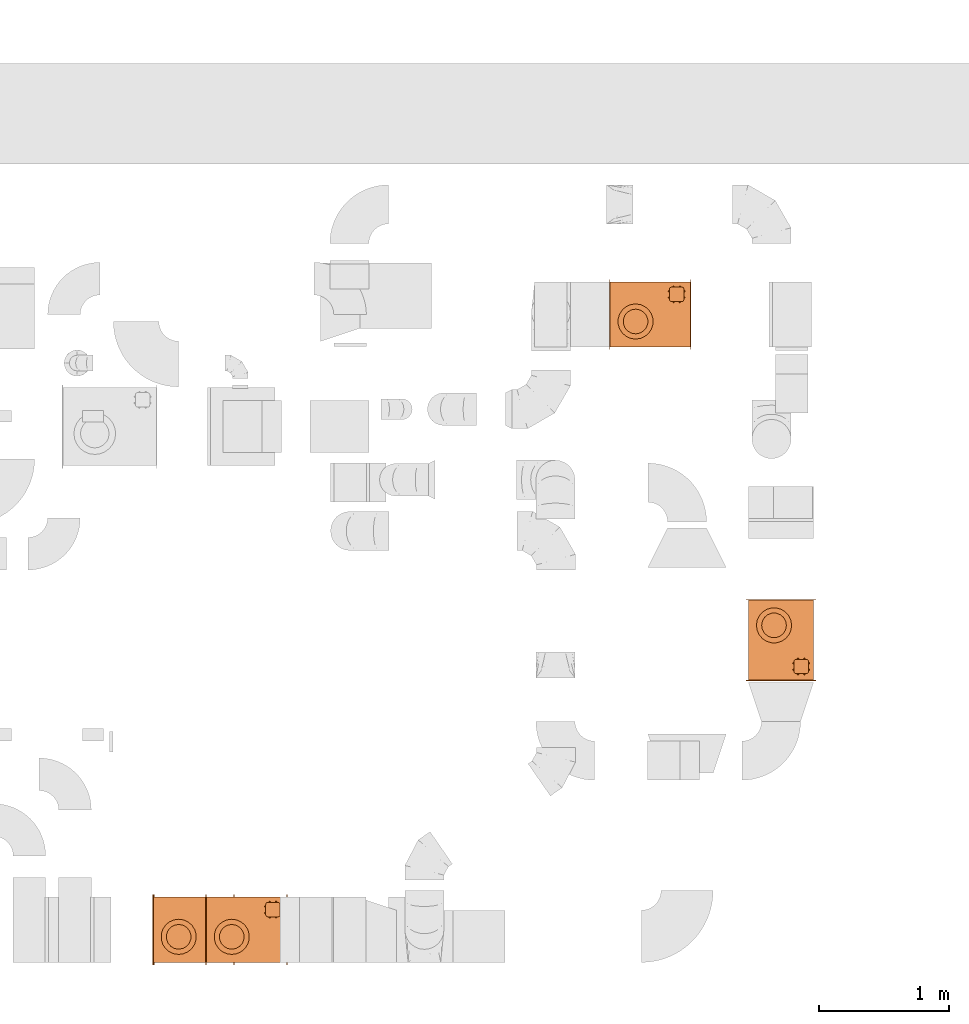
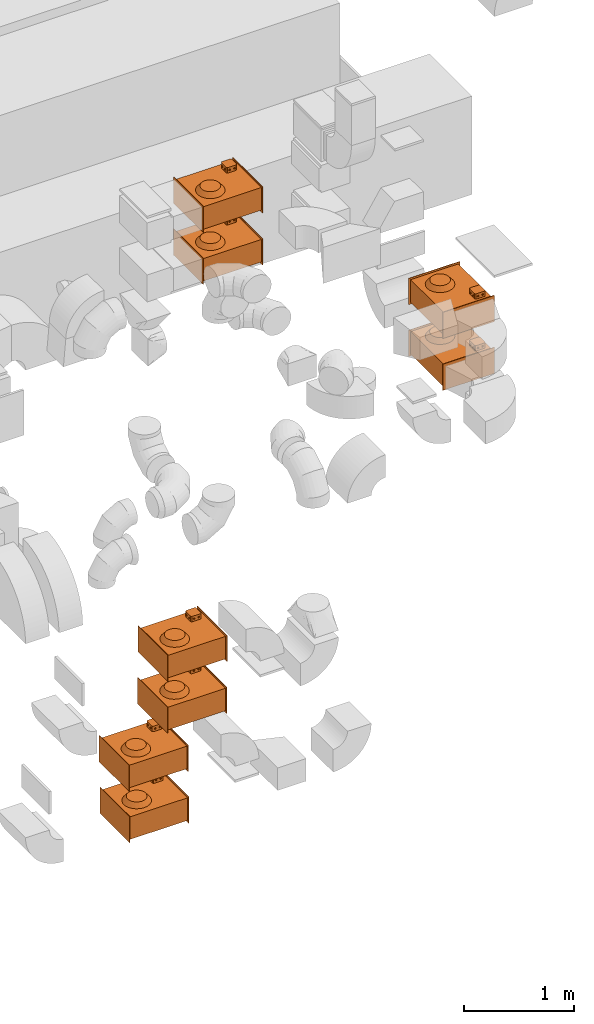
# One storey, part 59 of 59: 8 proxies.
"""IFC2X3 building model written with IfcOpenShell, lengths in millimetres."""

from ifc_helpers import new_model, entity, si_unit, converted_unit, derived_unit, direction, frame, origin, place, context, subcontext, project, spatial, faceted_brep, source, transform, mapped, material, material_list, type_object, type_shapes, element, save


model = new_model("IFC2X3")

# Units and contexts
model_context = context("Model", 3, precision=0.01, world=origin(), true_north=direction((6.12303176911189e-17, 1.0)))
body_context = subcontext(model_context, "Body", "Model", "MODEL_VIEW")
ifc_project = project(units=[si_unit("LENGTHUNIT", "METRE", prefix="MILLI"), si_unit("AREAUNIT", "SQUARE_METRE"), si_unit("VOLUMEUNIT", "CUBIC_METRE"), converted_unit("PLANEANGLEUNIT", "DEGREE", entity("IfcRatioMeasure", 0.0174532925199433), si_unit("PLANEANGLEUNIT", "RADIAN"), dimensions=[0, 0, 0, 0, 0, 0, 0]), si_unit("MASSUNIT", "GRAM", prefix="KILO"), derived_unit("MASSDENSITYUNIT", [(si_unit("MASSUNIT", "GRAM", prefix="KILO"), 1), (si_unit("LENGTHUNIT", "METRE"), -3)]), derived_unit("MOMENTOFINERTIAUNIT", [(si_unit("LENGTHUNIT", "METRE"), 4)]), si_unit("TIMEUNIT", "SECOND"), si_unit("FREQUENCYUNIT", "HERTZ"), si_unit("THERMODYNAMICTEMPERATUREUNIT", "DEGREE_CELSIUS"), derived_unit("THERMALTRANSMITTANCEUNIT", [(si_unit("MASSUNIT", "GRAM", prefix="KILO"), 1), (si_unit("THERMODYNAMICTEMPERATUREUNIT", "KELVIN"), -1), (si_unit("TIMEUNIT", "SECOND"), -3)]), derived_unit("VOLUMETRICFLOWRATEUNIT", [(si_unit("LENGTHUNIT", "METRE"), 3), (si_unit("TIMEUNIT", "SECOND"), -1)]), derived_unit("MASSFLOWRATEUNIT", [(si_unit("MASSUNIT", "GRAM", prefix="KILO"), 1), (si_unit("TIMEUNIT", "SECOND"), -1)]), derived_unit("ROTATIONALFREQUENCYUNIT", [(si_unit("TIMEUNIT", "SECOND"), -1)]), si_unit("ELECTRICCURRENTUNIT", "AMPERE"), si_unit("ELECTRICVOLTAGEUNIT", "VOLT"), si_unit("POWERUNIT", "WATT"), si_unit("FORCEUNIT", "NEWTON", prefix="KILO"), si_unit("ILLUMINANCEUNIT", "LUX"), si_unit("LUMINOUSFLUXUNIT", "LUMEN"), si_unit("LUMINOUSINTENSITYUNIT", "CANDELA"), derived_unit("USERDEFINED", [(si_unit("MASSUNIT", "GRAM", prefix="KILO"), -1), (si_unit("LENGTHUNIT", "METRE"), -2), (si_unit("TIMEUNIT", "SECOND"), 3), (si_unit("LUMINOUSFLUXUNIT", "LUMEN"), 1)]), derived_unit("LINEARVELOCITYUNIT", [(si_unit("LENGTHUNIT", "METRE"), 1), (si_unit("TIMEUNIT", "SECOND"), -1)]), si_unit("PRESSUREUNIT", "PASCAL"), derived_unit("USERDEFINED", [(si_unit("LENGTHUNIT", "METRE"), -2), (si_unit("MASSUNIT", "GRAM", prefix="KILO"), 1), (si_unit("TIMEUNIT", "SECOND"), -2)]), derived_unit("LINEARFORCEUNIT", [(si_unit("MASSUNIT", "GRAM", prefix="KILO"), 1), (si_unit("LENGTHUNIT", "METRE"), 1), (si_unit("TIMEUNIT", "SECOND"), -2), (si_unit("LENGTHUNIT", "METRE"), -1)]), derived_unit("PLANARFORCEUNIT", [(si_unit("MASSUNIT", "GRAM", prefix="KILO"), 1), (si_unit("LENGTHUNIT", "METRE"), 1), (si_unit("TIMEUNIT", "SECOND"), -2), (si_unit("LENGTHUNIT", "METRE"), -2)])], contexts=[model_context])

# Site, building, storey
site_placement = place(None, origin())
site = spatial("IfcSite", under=ifc_project, at=site_placement, CompositionType="ELEMENT")
building_placement = place(site_placement, origin())
building = spatial("IfcBuilding", under=site, at=building_placement, CompositionType="ELEMENT")
storey_placement = place(building_placement, frame((0.0, 0.0, 28200.0)))
storey = spatial("IfcBuildingStorey", under=building, at=storey_placement, CompositionType="ELEMENT", Elevation=28200.0)

# Proxies
ifc_material_1 = material()
ifc_material_2 = material()
ifc_material_list_1 = material_list([ifc_material_1, ifc_material_2])
ifc_material_3 = material()
ifc_material_list_2 = material_list([ifc_material_2, ifc_material_3, ifc_material_1])
building_element_proxy_type_1 = type_object("IfcBuildingElementProxyType", PredefinedType="NOTDEFINED", material=ifc_material_list_2)
shared_shape = source(origin(), body_context, "Body", "Brep", [
    faceted_brep([(-137.5, -132.29, 153.93), (-137.5, -130.29, 151.93), (-137.5, -128.29, 153.93), (-137.5, -130.29, 155.93), (-147.5, -125.29, 145.27), (-147.5, -135.29, 145.27), (-147.5, -140.29, 153.93), (-147.5, -135.29, 162.59), (-147.5, -125.29, 162.59), (-147.5, -120.29, 153.93)], [[[0, 1, 2, 3]], [[4, 5, 6, 7, 8, 9]], [[2, 4, 9]], [[4, 2, 1]], [[1, 0, 5]], [[6, 5, 0]], [[1, 5, 4]], [[0, 7, 6]], [[7, 0, 3]], [[3, 2, 8]], [[9, 8, 2]], [[3, 8, 7]]]),
    faceted_brep([(-137.5, -176.95, 153.93), (-137.5, -178.95, 155.93), (-137.5, -180.95, 153.93), (-137.5, -178.95, 151.93), (-147.5, -173.95, 162.59), (-147.5, -168.95, 153.93), (-147.5, -173.95, 145.27), (-147.5, -183.95, 145.27), (-147.5, -188.95, 153.93), (-147.5, -183.95, 162.59)], [[[0, 1, 2, 3]], [[4, 5, 6, 7, 8, 9]], [[0, 6, 5]], [[6, 0, 3]], [[3, 2, 7]], [[8, 7, 2]], [[3, 7, 6]], [[2, 9, 8]], [[9, 2, 1]], [[1, 0, 4]], [[5, 4, 0]], [[1, 4, 9]]]),
    faceted_brep([(-267.5, -132.29, 153.93), (-267.5, -130.29, 155.93), (-267.5, -128.29, 153.93), (-267.5, -130.29, 151.93), (-257.5, -135.29, 162.59), (-257.5, -140.29, 153.93), (-257.5, -135.29, 145.27), (-257.5, -125.29, 145.27), (-257.5, -120.29, 153.93), (-257.5, -125.29, 162.59)], [[[0, 1, 2, 3]], [[4, 5, 6, 7, 8, 9]], [[0, 6, 5]], [[6, 0, 3]], [[3, 2, 7]], [[8, 7, 2]], [[3, 7, 6]], [[2, 9, 8]], [[9, 2, 1]], [[1, 0, 4]], [[5, 4, 0]], [[1, 4, 9]]]),
    faceted_brep([(-267.5, -176.95, 153.93), (-267.5, -178.95, 151.93), (-267.5, -180.95, 153.93), (-267.5, -178.95, 155.93), (-257.5, -183.95, 145.27), (-257.5, -173.95, 145.27), (-257.5, -168.95, 153.93), (-257.5, -173.95, 162.59), (-257.5, -183.95, 162.59), (-257.5, -188.95, 153.93)], [[[0, 1, 2, 3]], [[4, 5, 6, 7, 8, 9]], [[2, 4, 9]], [[4, 2, 1]], [[1, 0, 5]], [[6, 5, 0]], [[1, 5, 4]], [[0, 7, 6]], [[7, 0, 3]], [[3, 2, 8]], [[9, 8, 2]], [[3, 8, 7]]]),
    faceted_brep([(-180.17, -90.0, 153.93), (-178.17, -90.0, 155.93), (-176.17, -90.0, 153.93), (-178.17, -90.0, 151.93), (-183.17, -100.0, 162.59), (-188.17, -100.0, 153.93), (-183.17, -100.0, 145.27), (-173.17, -100.0, 145.27), (-168.17, -100.0, 153.93), (-173.17, -100.0, 162.59)], [[[0, 1, 2, 3]], [[4, 5, 6, 7, 8, 9]], [[0, 6, 5]], [[6, 0, 3]], [[3, 2, 7]], [[8, 7, 2]], [[3, 7, 6]], [[2, 9, 8]], [[9, 2, 1]], [[1, 0, 4]], [[5, 4, 0]], [[1, 4, 9]]]),
    faceted_brep([(-224.83, -90.0, 153.93), (-226.83, -90.0, 151.93), (-228.83, -90.0, 153.93), (-226.83, -90.0, 155.93), (-221.83, -100.0, 145.27), (-216.83, -100.0, 153.93), (-221.83, -100.0, 162.59), (-231.83, -100.0, 162.59), (-236.83, -100.0, 153.93), (-231.83, -100.0, 145.27)], [[[0, 1, 2, 3]], [[4, 5, 6, 7, 8, 9]], [[2, 9, 8]], [[9, 2, 1]], [[1, 0, 4]], [[5, 4, 0]], [[1, 4, 9]], [[0, 6, 5]], [[6, 0, 3]], [[3, 2, 7]], [[8, 7, 2]], [[3, 7, 6]]]),
    faceted_brep([(-180.17, -220.0, 153.93), (-178.17, -220.0, 151.93), (-176.17, -220.0, 153.93), (-178.17, -220.0, 155.93), (-183.17, -210.0, 145.27), (-188.17, -210.0, 153.93), (-183.17, -210.0, 162.59), (-173.17, -210.0, 162.59), (-168.17, -210.0, 153.93), (-173.17, -210.0, 145.27)], [[[0, 1, 2, 3]], [[4, 5, 6, 7, 8, 9]], [[2, 9, 8]], [[9, 2, 1]], [[1, 0, 4]], [[5, 4, 0]], [[1, 4, 9]], [[0, 6, 5]], [[6, 0, 3]], [[3, 2, 7]], [[8, 7, 2]], [[3, 7, 6]]]),
    faceted_brep([(-224.83, -220.0, 153.93), (-226.83, -220.0, 155.93), (-228.83, -220.0, 153.93), (-226.83, -220.0, 151.93), (-231.83, -210.0, 162.59), (-221.83, -210.0, 162.59), (-216.83, -210.0, 153.93), (-221.83, -210.0, 145.27), (-231.83, -210.0, 145.27), (-236.83, -210.0, 153.93)], [[[0, 1, 2, 3]], [[4, 5, 6, 7, 8, 9]], [[0, 7, 6]], [[7, 0, 3]], [[3, 2, 8]], [[9, 8, 2]], [[3, 8, 7]], [[2, 4, 9]], [[4, 2, 1]], [[1, 0, 5]], [[6, 5, 0]], [[1, 5, 4]]]),
    faceted_brep([(-162.5, -100.0, 185.0), (-242.5, -100.0, 185.0), (-246.38, -100.51, 185.0), (-250.0, -102.01, 185.0), (-253.11, -104.39, 185.0), (-255.49, -107.5, 185.0), (-256.99, -111.12, 185.0), (-257.5, -115.0, 185.0), (-257.5, -195.0, 185.0), (-256.99, -198.88, 185.0), (-255.49, -202.5, 185.0), (-253.11, -205.61, 185.0), (-250.0, -207.99, 185.0), (-246.38, -209.49, 185.0), (-242.5, -210.0, 185.0), (-162.5, -210.0, 185.0), (-158.62, -209.49, 185.0), (-155.0, -207.99, 185.0), (-151.89, -205.61, 185.0), (-149.51, -202.5, 185.0), (-148.01, -198.88, 185.0), (-147.5, -195.0, 185.0), (-147.5, -115.0, 185.0), (-148.01, -111.12, 185.0), (-149.51, -107.5, 185.0), (-151.89, -104.39, 185.0), (-155.0, -102.01, 185.0), (-158.62, -100.51, 185.0), (-246.38, -100.51, 125.0), (-242.5, -100.0, 125.0), (-162.5, -100.0, 125.0), (-158.62, -100.51, 125.0), (-155.0, -102.01, 125.0), (-151.89, -104.39, 125.0), (-149.51, -107.5, 125.0), (-148.01, -111.12, 125.0), (-147.5, -115.0, 125.0), (-147.5, -195.0, 125.0), (-148.01, -198.88, 125.0), (-149.51, -202.5, 125.0), (-151.89, -205.61, 125.0), (-155.0, -207.99, 125.0), (-158.62, -209.49, 125.0), (-162.5, -210.0, 125.0), (-242.5, -210.0, 125.0), (-246.38, -209.49, 125.0), (-250.0, -207.99, 125.0), (-253.11, -205.61, 125.0), (-255.49, -202.5, 125.0), (-256.99, -198.88, 125.0), (-257.5, -195.0, 125.0), (-257.5, -115.0, 125.0), (-256.99, -111.12, 125.0), (-255.49, -107.5, 125.0), (-253.11, -104.39, 125.0), (-250.0, -102.01, 125.0)], [[[0, 1, 2, 3, 4, 5, 6, 7, 8, 9, 10, 11, 12, 13, 14, 15, 16, 17, 18, 19, 20, 21, 22, 23, 24, 25, 26, 27]], [[28, 29, 30, 31, 32, 33, 34, 35, 36, 37, 38, 39, 40, 41, 42, 43, 44, 45, 46, 47, 48, 49, 50, 51, 52, 53, 54, 55]], [[1, 0, 30, 29]], [[2, 28, 55, 3]], [[3, 55, 54, 4]], [[29, 28, 2, 1]], [[5, 53, 52, 6]], [[6, 52, 51, 7]], [[4, 54, 53, 5]], [[8, 7, 51, 50]], [[9, 49, 48, 10]], [[10, 48, 47, 11]], [[50, 49, 9, 8]], [[12, 46, 45, 13]], [[13, 45, 44, 14]], [[11, 47, 46, 12]], [[15, 14, 44, 43]], [[16, 42, 41, 17]], [[17, 41, 40, 18]], [[43, 42, 16, 15]], [[19, 39, 38, 20]], [[20, 38, 37, 21]], [[18, 40, 39, 19]], [[22, 21, 37, 36]], [[23, 35, 34, 24]], [[24, 34, 33, 25]], [[36, 35, 23, 22]], [[26, 32, 31, 27]], [[27, 31, 30, 0]], [[25, 33, 32, 26]]]),
    faceted_brep([(312.5, -270.0, 145.0), (312.5, -270.0, -145.0), (312.5, 270.0, -145.0), (312.5, 270.0, 145.0), (307.5, -270.0, 145.0), (307.5, 270.0, 145.0), (307.5, 270.0, -145.0), (307.5, -270.0, -145.0)], [[[0, 1, 2, 3]], [[4, 5, 6, 7]], [[1, 0, 4, 7]], [[2, 1, 7, 6]], [[3, 2, 6, 5]], [[0, 3, 5, 4]]]),
    faceted_brep([(-307.5, -270.0, 145.0), (-307.5, -270.0, -145.0), (-307.5, 270.0, -145.0), (-307.5, 270.0, 145.0), (-312.5, -270.0, 145.0), (-312.5, 270.0, 145.0), (-312.5, 270.0, -145.0), (-312.5, -270.0, -145.0)], [[[0, 1, 2, 3]], [[4, 5, 6, 7]], [[1, 0, 4, 7]], [[2, 1, 7, 6]], [[3, 2, 6, 5]], [[0, 3, 5, 4]]]),
    faceted_brep([(307.5, -250.0, 125.0), (307.5, -250.0, -125.0), (307.5, 250.0, -125.0), (307.5, 250.0, 125.0), (-307.5, -250.0, 125.0), (-307.5, 250.0, 125.0), (-307.5, 250.0, -125.0), (-307.5, -250.0, -125.0)], [[[0, 1, 2, 3]], [[4, 5, 6, 7]], [[1, 0, 4, 7]], [[2, 1, 7, 6]], [[3, 2, 6, 5]], [[0, 3, 5, 4]]]),
    faceted_brep([(206.78, 37.14, 173.0), (206.78, 70.13, 173.0), (195.5, 101.14, 173.0), (174.29, 126.41, 173.0), (145.72, 142.91, 173.0), (113.22, 148.64, 173.0), (80.73, 142.91, 173.0), (52.16, 126.41, 173.0), (30.95, 101.14, 173.0), (19.67, 70.13, 173.0), (19.67, 37.14, 173.0), (30.95, 6.14, 173.0), (52.16, -19.14, 173.0), (80.73, -35.63, 173.0), (113.22, -41.36, 173.0), (145.72, -35.63, 173.0), (174.29, -19.14, 173.0), (195.5, 6.14, 173.0), (236.02, 109.72, 125.0), (246.85, 72.85, 125.0), (246.85, 34.42, 125.0), (236.02, -2.44, 125.0), (215.25, -34.77, 125.0), (186.21, -59.93, 125.0), (151.26, -75.89, 125.0), (113.22, -81.36, 125.0), (75.19, -75.89, 125.0), (40.24, -59.93, 125.0), (11.2, -34.77, 125.0), (-9.58, -2.44, 125.0), (-20.4, 34.42, 125.0), (-20.4, 72.85, 125.0), (-9.58, 109.72, 125.0), (11.2, 142.04, 125.0), (40.24, 167.21, 125.0), (75.19, 183.17, 125.0), (113.22, 188.64, 125.0), (151.26, 183.17, 125.0), (186.21, 167.21, 125.0), (215.25, 142.04, 125.0)], [[[0, 1, 2, 3, 4, 5, 6, 7, 8, 9, 10, 11, 12, 13, 14, 15, 16, 17]], [[18, 19, 20, 21, 22, 23, 24, 25, 26, 27, 28, 29, 30, 31, 32, 33, 34, 35, 36, 37, 38, 39]], [[14, 13, 26]], [[11, 10, 29]], [[12, 11, 28]], [[13, 12, 27]], [[13, 27, 26]], [[26, 25, 14]], [[28, 27, 12]], [[29, 28, 11]], [[10, 30, 29]], [[10, 9, 31, 30]], [[9, 8, 32]], [[6, 5, 35]], [[7, 6, 34]], [[8, 7, 33]], [[8, 33, 32]], [[32, 31, 9]], [[34, 33, 7]], [[35, 34, 6]], [[5, 36, 35]], [[5, 4, 37]], [[2, 1, 18]], [[3, 2, 39]], [[4, 3, 38]], [[4, 38, 37]], [[37, 36, 5]], [[39, 38, 3]], [[18, 39, 2]], [[1, 19, 18]], [[1, 0, 20, 19]], [[0, 17, 21]], [[15, 14, 24]], [[16, 15, 23]], [[17, 16, 22]], [[17, 22, 21]], [[21, 20, 0]], [[23, 22, 16]], [[24, 23, 15]], [[14, 25, 24]]]),
])
type_shapes(building_element_proxy_type_1, [shared_shape])
for number, where, z_axis, x_axis in (
    (1, (29946.35, 8184.5, 425.0), (0.0, 0.0, 1.0), (-1.0, 0.0, 0.0)),
    (2, (29938.34, 8184.5, 1000.0), (0.0, 0.0, 1.0), (-1.0, 0.0, 0.0)),
    (3, (30342.86, 8184.5, 1500.0), (0.0, 0.0, 1.0), (-1.0, 0.0, 0.0)),
    (4, (30345.56, 8184.5, 2075.0), (0.0, 0.0, 1.0), (-1.0, 0.0, 0.0)),
    (5, (34445.98, 10406.86, 3100.0), (0.0, 0.0, 1.0), (0.0, 1.0, 0.0)),
    (6, (34445.98, 10407.18, 2525.0), (0.0, 0.0, 1.0), (0.0, 1.0, 0.0)),
):
    element("IfcBuildingElementProxy", number, at=place(storey_placement, frame(where, z_axis=z_axis, x_axis=x_axis)), inside=storey, type_object=building_element_proxy_type_1, material=ifc_material_list_1, context=body_context, shape_type="MappedRepresentation", body=[
        mapped(shared_shape, transform((0.0, 0.0, 0.0), scale=1.0)),
    ])
building_element_proxy_type_2 = type_object("IfcBuildingElementProxyType", PredefinedType="NOTDEFINED", material=ifc_material_list_2)
type_shapes(building_element_proxy_type_2, [shared_shape])
for number, where, z_axis, x_axis in (
    (7, (33443.32, 12904.98, 3100.0), (0.0, 0.0, 1.0), (-1.0, 0.0, 0.0)),
    (8, (33443.32, 12904.98, 2525.0), (0.0, 0.0, 1.0), (-1.0, 0.0, 0.0)),
):
    element("IfcBuildingElementProxy", number, at=place(storey_placement, frame(where, z_axis=z_axis, x_axis=x_axis)), inside=storey, type_object=building_element_proxy_type_2, material=ifc_material_list_1, context=body_context, shape_type="MappedRepresentation", body=[
        mapped(shared_shape, transform((0.0, 0.0, 0.0), scale=1.0)),
    ])

save(model, "model.ifc")
